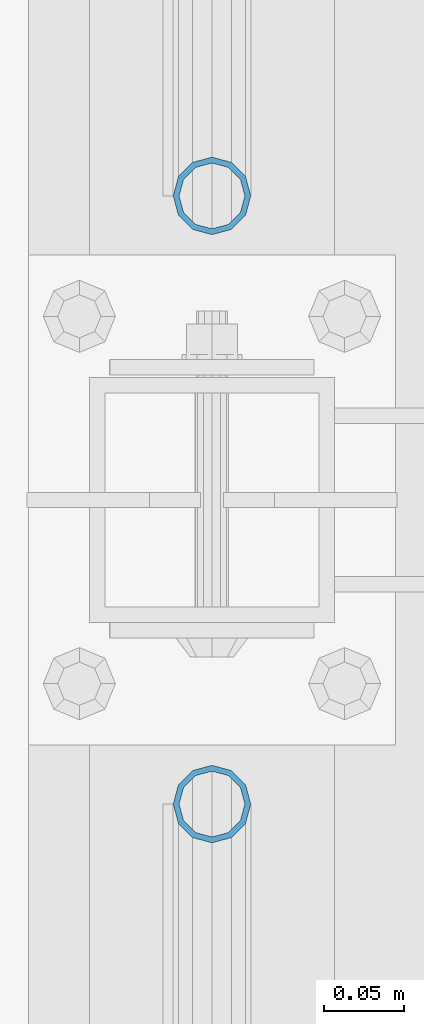
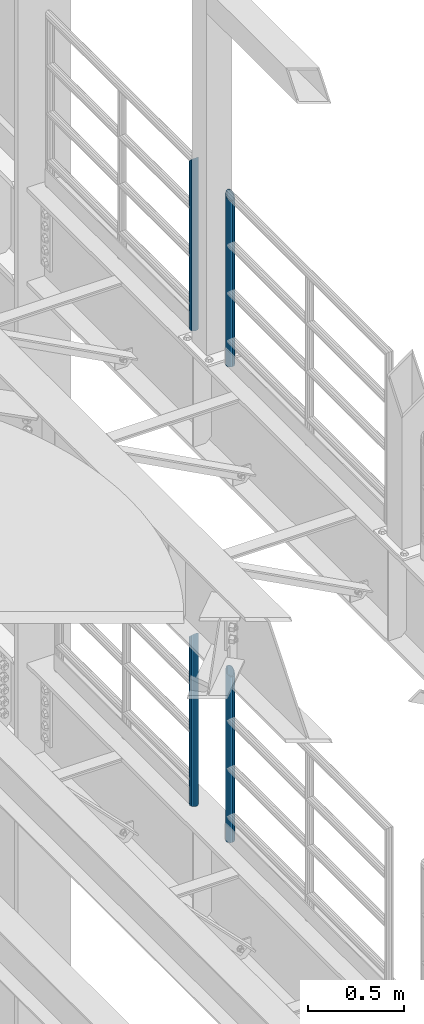
# One storey, part 708 of 1876: 4 columns, 4 elements without a shape of their own.
"""IFC2X3 building model written with IfcOpenShell, lengths in millimetres."""

from ifc_helpers import new_model, si_unit, frame, origin_with_axes, place, context, subcontext, project, spatial, faceted_brep, material, type_object, element, aggregate, save


model = new_model("IFC2X3")

# Units and contexts
model_context = context("Model", 3, precision=1e-05, world=origin_with_axes())
body_context = subcontext(model_context, "Body", "Model", "MODEL_VIEW")
ifc_project = project(units=[si_unit("LENGTHUNIT", "METRE", prefix="MILLI"), si_unit("AREAUNIT", "SQUARE_METRE"), si_unit("VOLUMEUNIT", "CUBIC_METRE"), si_unit("MASSUNIT", "GRAM", prefix="KILO"), si_unit("TIMEUNIT", "SECOND"), si_unit("PLANEANGLEUNIT", "RADIAN"), si_unit("SOLIDANGLEUNIT", "STERADIAN"), si_unit("THERMODYNAMICTEMPERATUREUNIT", "DEGREE_CELSIUS"), si_unit("LUMINOUSINTENSITYUNIT", "LUMEN")], contexts=[model_context])

# Site, building, storey
site_placement = place(None, origin_with_axes())
site = spatial("IfcSite", under=ifc_project, at=site_placement, CompositionType="ELEMENT")
building_placement = place(site_placement, origin_with_axes())
building = spatial("IfcBuilding", under=site, at=building_placement, Name="Undefined", CompositionType="ELEMENT")
storey_placement = place(building_placement, origin_with_axes())
storey = spatial("IfcBuildingStorey", under=building, at=storey_placement, Name="Undefined", CompositionType="ELEMENT", Elevation=0.0)

# Assembly, column
assembly_1_placement = place(storey_placement, origin_with_axes())
assembly_1 = element("IfcElementAssembly", 1, at=assembly_1_placement, inside=storey, Name="RAIL", AssemblyPlace="NOTDEFINED", PredefinedType="RIGID_FRAME")
ifc_material = material()
column_type = type_object("IfcColumnType", Name="PIPE1-1/2SCH40", PredefinedType="NOTDEFINED")
column_1_placement = place(assembly_1_placement, frame((7620.0, -318.770000000001, 8153.4), z_axis=(0.0, 1.0, 0.0), x_axis=(0.0, 0.0, 1.0)))
column_1 = element("IfcColumn", 2, at=column_1_placement, type_object=column_type, material=ifc_material, Name="POST", ObjectType="PIPE1-1/2SCH40", context=body_context, shape_type="Brep", body=[
    faceted_brep([(0.0, -20.4469999999999, 0.0), (0.0, -17.7076214311803, 10.2235000000001), (1066.1015, -17.7076214311803, 10.2235000000001), (1076.325, -20.4469999999999, 0.0), (0.0, -10.2235000000001, 17.7076214311801), (1058.61737856882, -10.2235000000001, 17.7076214311801), (-1.45519152283669e-11, 0.0, 20.4470000000001), (1055.878, 0.0, 20.4470000000001), (0.0, 10.2235000000001, 17.7076214311801), (1058.61737856882, 10.2235000000001, 17.7076214311801), (0.0, 17.7076214311803, 10.2235000000001), (1066.1015, 17.7076214311803, 10.2235000000001), (0.0, 20.4469999999999, 0.0), (1076.325, 20.4469999999999, 0.0), (0.0, 17.7076214311803, -10.2235000000001), (1086.5485, 17.7076214311803, -10.2235000000001), (0.0, 10.2235000000001, -17.7076214311801), (1094.03262143118, 10.2235000000001, -17.7076214311801), (-1.45519152283669e-11, 0.0, -20.4470000000001), (1096.772, 0.0, -20.4470000000001), (0.0, -10.2235000000001, -17.7076214311801), (1094.03262143118, -10.2235000000001, -17.7076214311801), (0.0, -17.7076214311803, -10.2235000000001), (1086.5485, -17.7076214311803, -10.2235000000001), (0.0, -24.1299999999992, 0.0), (0.0, -20.8971929933184, -12.0649999999996), (1088.39, -20.8971929933184, -12.0649999999996), (1076.325, -24.1300000000001, 0.0), (0.0, -12.0650000000001, -20.8971929933186), (1097.22219299332, -12.0650000000001, -20.8971929933186), (-1.45519152283669e-11, 0.0, -24.130000000001), (1100.455, 0.0, -24.1300000000001), (0.0, 12.0650000000001, -20.8971929933186), (1097.22219299332, 12.0650000000001, -20.8971929933186), (0.0, 20.8971929933184, -12.0649999999996), (1088.39, 20.8971929933184, -12.0649999999996), (0.0, 24.1299999999992, 0.0), (1076.325, 24.1300000000001, 0.0), (0.0, 20.8971929933184, 12.0649999999996), (1064.26, 20.8971929933184, 12.0649999999996), (0.0, 12.0650000000001, 20.8971929933186), (1055.42780700668, 12.0650000000001, 20.8971929933186), (-1.45519152283669e-11, 0.0, 24.130000000001), (1052.195, 0.0, 24.1300000000001), (0.0, -12.0650000000001, 20.8971929933186), (1055.42780700668, -12.0650000000001, 20.8971929933186), (0.0, -20.8971929933184, 12.0649999999996), (1064.26, -20.8971929933184, 12.0649999999996)], [[[0, 1, 2, 3]], [[1, 4, 5, 2]], [[4, 6, 7, 5]], [[6, 8, 9, 7]], [[8, 10, 11, 9]], [[10, 12, 13, 11]], [[12, 14, 15, 13]], [[14, 16, 17, 15]], [[16, 18, 19, 17]], [[18, 20, 21, 19]], [[20, 22, 23, 21]], [[22, 0, 3, 23]], [[24, 25, 26, 27]], [[25, 28, 29, 26]], [[28, 30, 31, 29]], [[30, 32, 33, 31]], [[32, 34, 35, 33]], [[34, 36, 37, 35]], [[36, 38, 39, 37]], [[38, 40, 41, 39]], [[40, 42, 43, 41]], [[42, 44, 45, 43]], [[44, 46, 47, 45]], [[46, 24, 27, 47]], [[29, 31, 33, 35, 37, 39, 41, 43, 45, 47, 27, 26], [5, 7, 9, 11, 13, 15, 17, 19, 21, 23, 3, 2]], [[46, 44, 42, 40, 38, 36, 34, 32, 30, 28, 25, 24], [22, 20, 18, 16, 14, 12, 10, 8, 6, 4, 1, 0]]]),
])
aggregate(assembly_1, [column_1])

assembly_2_placement = place(storey_placement, origin_with_axes())
assembly_2 = element("IfcElementAssembly", 3, at=assembly_2_placement, inside=storey, Name="RAIL", AssemblyPlace="NOTDEFINED", PredefinedType="RIGID_FRAME")
column_2_placement = place(assembly_2_placement, frame((7620.0, -697.230000000001, 8153.4), z_axis=(0.0, 1.0, 0.0), x_axis=(0.0, 0.0, 1.0)))
column_2 = element("IfcColumn", 4, at=column_2_placement, type_object=column_type, material=ifc_material, Name="POST", ObjectType="PIPE1-1/2SCH40", context=body_context, shape_type="Brep", body=[
    faceted_brep([(0.0, -20.4469999999999, 0.0), (0.0, -17.7076214311803, 10.2235000000001), (1086.54849999999, -17.7076214311801, 10.2235000000001), (1076.325, -20.4469999999999, 0.0), (0.0, -10.2235000000001, 17.7076214311801), (1094.03262143117, -10.2235000000001, 17.7076214311801), (-1.45519152283669e-11, 0.0, 20.4470000000001), (1096.77199999999, 0.0, 20.4470000000001), (0.0, 10.2235000000001, 17.7076214311801), (1094.03262143117, 10.2235000000001, 17.7076214311801), (0.0, 17.7076214311803, 10.2235000000001), (1086.54849999999, 17.7076214311801, 10.2235000000001), (0.0, 20.4469999999999, 0.0), (1076.325, 20.4469999999999, 0.0), (0.0, 17.7076214311803, -10.2235000000001), (1066.10149999999, 17.7076214311801, -10.2235000000001), (0.0, 10.2235000000001, -17.7076214311801), (1058.61737856881, 10.2235000000001, -17.7076214311801), (-1.45519152283669e-11, 0.0, -20.4470000000001), (1055.87799999999, 0.0, -20.4470000000001), (0.0, -10.2235000000001, -17.7076214311801), (1058.61737856881, -10.2235000000001, -17.7076214311801), (0.0, -17.7076214311803, -10.2235000000001), (1066.10149999999, -17.7076214311801, -10.2235000000001), (0.0, -24.1299999999992, 0.0), (0.0, -20.8971929933184, -12.0649999999996), (1064.25999999999, -20.8971929933186, -12.0649999999996), (1076.325, -24.1300000000001, 0.0), (0.0, -12.0650000000001, -20.8971929933186), (1055.42780700667, -12.0649999999996, -20.8971929933186), (-1.45519152283669e-11, 0.0, -24.130000000001), (1052.19499999999, 0.0, -24.1300000000001), (0.0, 12.0650000000001, -20.8971929933186), (1055.42780700667, 12.0649999999996, -20.8971929933186), (0.0, 20.8971929933184, -12.0649999999996), (1064.25999999999, 20.8971929933186, -12.0649999999996), (0.0, 24.1299999999992, 0.0), (1076.325, 24.1300000000001, 0.0), (0.0, 20.8971929933184, 12.0649999999996), (1088.38999999999, 20.8971929933186, 12.0649999999996), (0.0, 12.0650000000001, 20.8971929933186), (1097.22219299331, 12.0649999999996, 20.8971929933186), (-1.45519152283669e-11, 0.0, 24.130000000001), (1100.45499999999, 0.0, 24.1300000000001), (0.0, -12.0650000000001, 20.8971929933186), (1097.22219299331, -12.0649999999996, 20.8971929933186), (0.0, -20.8971929933184, 12.0649999999996), (1088.38999999999, -20.8971929933186, 12.0649999999996)], [[[0, 1, 2, 3]], [[1, 4, 5, 2]], [[4, 6, 7, 5]], [[6, 8, 9, 7]], [[8, 10, 11, 9]], [[10, 12, 13, 11]], [[12, 14, 15, 13]], [[14, 16, 17, 15]], [[16, 18, 19, 17]], [[18, 20, 21, 19]], [[20, 22, 23, 21]], [[22, 0, 3, 23]], [[24, 25, 26, 27]], [[25, 28, 29, 26]], [[28, 30, 31, 29]], [[30, 32, 33, 31]], [[32, 34, 35, 33]], [[34, 36, 37, 35]], [[36, 38, 39, 37]], [[38, 40, 41, 39]], [[40, 42, 43, 41]], [[42, 44, 45, 43]], [[44, 46, 47, 45]], [[46, 24, 27, 47]], [[29, 31, 33, 35, 37, 39, 41, 43, 45, 47, 27, 26], [5, 7, 9, 11, 13, 15, 17, 19, 21, 23, 3, 2]], [[46, 44, 42, 40, 38, 36, 34, 32, 30, 28, 25, 24], [22, 20, 18, 16, 14, 12, 10, 8, 6, 4, 1, 0]]]),
])
aggregate(assembly_2, [column_2])

assembly_3_placement = place(storey_placement, origin_with_axes())
assembly_3 = element("IfcElementAssembly", 5, at=assembly_3_placement, inside=storey, Name="RAIL", AssemblyPlace="NOTDEFINED", PredefinedType="RIGID_FRAME")
column_3_placement = place(assembly_3_placement, frame((7620.0, -318.770000000004, 5130.8), z_axis=(0.0, 1.0, 0.0), x_axis=(0.0, 0.0, 1.0)))
column_3 = element("IfcColumn", 6, at=column_3_placement, type_object=column_type, material=ifc_material, Name="POST", ObjectType="PIPE1-1/2SCH40", context=body_context, shape_type="Brep", body=[
    faceted_brep([(0.0, -20.4469999999999, 0.0), (0.0, -17.7076214311803, 10.2235000000001), (1066.10158618498, -17.7076214311801, 10.2235000000001), (1076.325, -20.4469999999999, 0.0), (0.0, -10.2235000000001, 17.7076214311801), (1058.61752784562, -10.2235000000001, 17.7076214311801), (-1.45519152283669e-11, 0.0, 20.4470000000001), (1055.87817237002, 0.0, 20.4470000000001), (0.0, 10.2235000000001, 17.7076214311801), (1058.61752784562, 10.2235000000001, 17.7076214311801), (0.0, 17.7076214311803, 10.2235000000001), (1066.10158618498, 17.7076214311801, 10.2235000000001), (0.0, 20.4469999999999, 0.0), (1076.325, 20.4469999999999, 0.0), (0.0, 17.7076214311803, -10.2235000000001), (1086.54841381489, 17.7076214311801, -10.2235000000001), (0.0, 10.2235000000001, -17.7076214311801), (1094.03247215425, 10.2235000000001, -17.7076214311801), (-1.45519152283669e-11, 0.0, -20.4470000000001), (1096.77182762985, 0.0, -20.4470000000001), (0.0, -10.2235000000001, -17.7076214311801), (1094.03247215425, -10.2235000000001, -17.7076214311801), (0.0, -17.7076214311803, -10.2235000000001), (1086.54841381489, -17.7076214311801, -10.2235000000001), (0.0, -24.1299999999992, 0.0), (0.0, -20.8971929933184, -12.0649999999996), (1088.38989829088, -20.8971929933186, -12.0649999999996), (1076.325, -24.1300000000001, 0.0), (0.0, -12.0650000000001, -20.8971929933186), (1097.222016828, -12.0649999999996, -20.8971929933186), (-1.45519152283669e-11, 0.0, -24.130000000001), (1100.45479658183, 0.0, -24.1300000000001), (0.0, 12.0650000000001, -20.8971929933186), (1097.222016828, 12.0649999999996, -20.8971929933186), (0.0, 20.8971929933184, -12.0649999999996), (1088.38989829088, 20.8971929933186, -12.0649999999996), (0.0, 24.1299999999992, 0.0), (1076.325, 24.1300000000001, 0.0), (0.0, 20.8971929933184, 12.0649999999996), (1064.26010170542, 20.8971929933186, 12.0650000000001), (0.0, 12.0650000000001, 20.8971929933186), (1055.42798316718, 12.0649999999996, 20.8971929933186), (-1.45519152283669e-11, 0.0, 24.130000000001), (1052.19520341295, 0.0, 24.1300000000001), (0.0, -12.0650000000001, 20.8971929933186), (1055.42798316718, -12.0649999999996, 20.8971929933186), (0.0, -20.8971929933184, 12.0649999999996), (1064.26010170542, -20.8971929933186, 12.0650000000001)], [[[0, 1, 2, 3]], [[1, 4, 5, 2]], [[4, 6, 7, 5]], [[6, 8, 9, 7]], [[8, 10, 11, 9]], [[10, 12, 13, 11]], [[12, 14, 15, 13]], [[14, 16, 17, 15]], [[16, 18, 19, 17]], [[18, 20, 21, 19]], [[20, 22, 23, 21]], [[22, 0, 3, 23]], [[24, 25, 26, 27]], [[25, 28, 29, 26]], [[28, 30, 31, 29]], [[30, 32, 33, 31]], [[32, 34, 35, 33]], [[34, 36, 37, 35]], [[36, 38, 39, 37]], [[38, 40, 41, 39]], [[40, 42, 43, 41]], [[42, 44, 45, 43]], [[44, 46, 47, 45]], [[46, 24, 27, 47]], [[29, 31, 33, 35, 37, 39, 41, 43, 45, 47, 27, 26], [5, 7, 9, 11, 13, 15, 17, 19, 21, 23, 3, 2]], [[46, 44, 42, 40, 38, 36, 34, 32, 30, 28, 25, 24], [22, 20, 18, 16, 14, 12, 10, 8, 6, 4, 1, 0]]]),
])
aggregate(assembly_3, [column_3])

assembly_4_placement = place(storey_placement, origin_with_axes())
assembly_4 = element("IfcElementAssembly", 7, at=assembly_4_placement, inside=storey, Name="RAIL", AssemblyPlace="NOTDEFINED", PredefinedType="RIGID_FRAME")
column_4_placement = place(assembly_4_placement, frame((7620.0, -697.230000000005, 5130.8), z_axis=(0.0, 1.0, 0.0), x_axis=(0.0, 0.0, 1.0)))
column_4 = element("IfcColumn", 8, at=column_4_placement, type_object=column_type, material=ifc_material, Name="POST", ObjectType="PIPE1-1/2SCH40", context=body_context, shape_type="Brep", body=[
    faceted_brep([(0.0, -20.4469999999999, 0.0), (0.0, -17.7076214311803, 10.2235000000001), (1086.54849999999, -17.7076214311801, 10.2235000000001), (1076.325, -20.4469999999999, 0.0), (0.0, -10.2235000000001, 17.7076214311801), (1094.03262143117, -10.2235000000001, 17.7076214311801), (-1.45519152283669e-11, 0.0, 20.4470000000001), (1096.77199999999, 0.0, 20.4470000000001), (0.0, 10.2235000000001, 17.7076214311801), (1094.03262143117, 10.2235000000001, 17.7076214311801), (0.0, 17.7076214311803, 10.2235000000001), (1086.54849999999, 17.7076214311801, 10.2235000000001), (0.0, 20.4469999999999, 0.0), (1076.325, 20.4469999999999, 0.0), (0.0, 17.7076214311803, -10.2235000000001), (1066.10149999999, 17.7076214311801, -10.2235000000001), (0.0, 10.2235000000001, -17.7076214311801), (1058.61737856881, 10.2235000000001, -17.7076214311801), (-1.45519152283669e-11, 0.0, -20.4470000000001), (1055.87799999999, 0.0, -20.4470000000001), (0.0, -10.2235000000001, -17.7076214311801), (1058.61737856881, -10.2235000000001, -17.7076214311801), (0.0, -17.7076214311803, -10.2235000000001), (1066.10149999999, -17.7076214311801, -10.2235000000001), (0.0, -24.1299999999992, 0.0), (0.0, -20.8971929933184, -12.0649999999996), (1064.25999999999, -20.8971929933186, -12.0649999999996), (1076.325, -24.1300000000001, 0.0), (0.0, -12.0650000000001, -20.8971929933186), (1055.42780700667, -12.0649999999996, -20.8971929933186), (-1.45519152283669e-11, 0.0, -24.130000000001), (1052.19499999999, 0.0, -24.1300000000001), (0.0, 12.0650000000001, -20.8971929933186), (1055.42780700667, 12.0649999999996, -20.8971929933186), (0.0, 20.8971929933184, -12.0649999999996), (1064.25999999999, 20.8971929933186, -12.0649999999996), (0.0, 24.1299999999992, 0.0), (1076.325, 24.1300000000001, 0.0), (0.0, 20.8971929933184, 12.0649999999996), (1088.38999999999, 20.8971929933186, 12.0649999999996), (0.0, 12.0650000000001, 20.8971929933186), (1097.22219299331, 12.0649999999996, 20.8971929933186), (-1.45519152283669e-11, 0.0, 24.130000000001), (1100.45499999999, 0.0, 24.1300000000001), (0.0, -12.0650000000001, 20.8971929933186), (1097.22219299331, -12.0649999999996, 20.8971929933186), (0.0, -20.8971929933184, 12.0649999999996), (1088.38999999999, -20.8971929933186, 12.0649999999996)], [[[0, 1, 2, 3]], [[1, 4, 5, 2]], [[4, 6, 7, 5]], [[6, 8, 9, 7]], [[8, 10, 11, 9]], [[10, 12, 13, 11]], [[12, 14, 15, 13]], [[14, 16, 17, 15]], [[16, 18, 19, 17]], [[18, 20, 21, 19]], [[20, 22, 23, 21]], [[22, 0, 3, 23]], [[24, 25, 26, 27]], [[25, 28, 29, 26]], [[28, 30, 31, 29]], [[30, 32, 33, 31]], [[32, 34, 35, 33]], [[34, 36, 37, 35]], [[36, 38, 39, 37]], [[38, 40, 41, 39]], [[40, 42, 43, 41]], [[42, 44, 45, 43]], [[44, 46, 47, 45]], [[46, 24, 27, 47]], [[29, 31, 33, 35, 37, 39, 41, 43, 45, 47, 27, 26], [5, 7, 9, 11, 13, 15, 17, 19, 21, 23, 3, 2]], [[46, 44, 42, 40, 38, 36, 34, 32, 30, 28, 25, 24], [22, 20, 18, 16, 14, 12, 10, 8, 6, 4, 1, 0]]]),
])
aggregate(assembly_4, [column_4])

save(model, "model.ifc")
